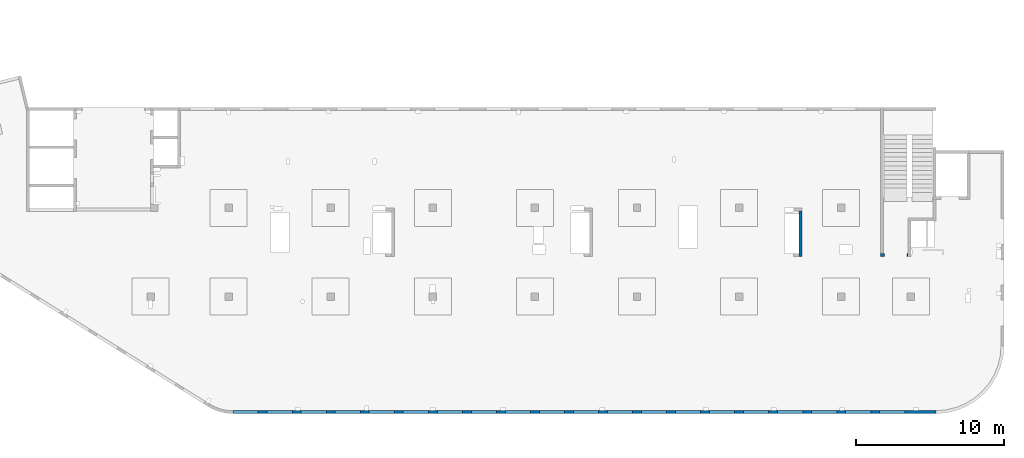
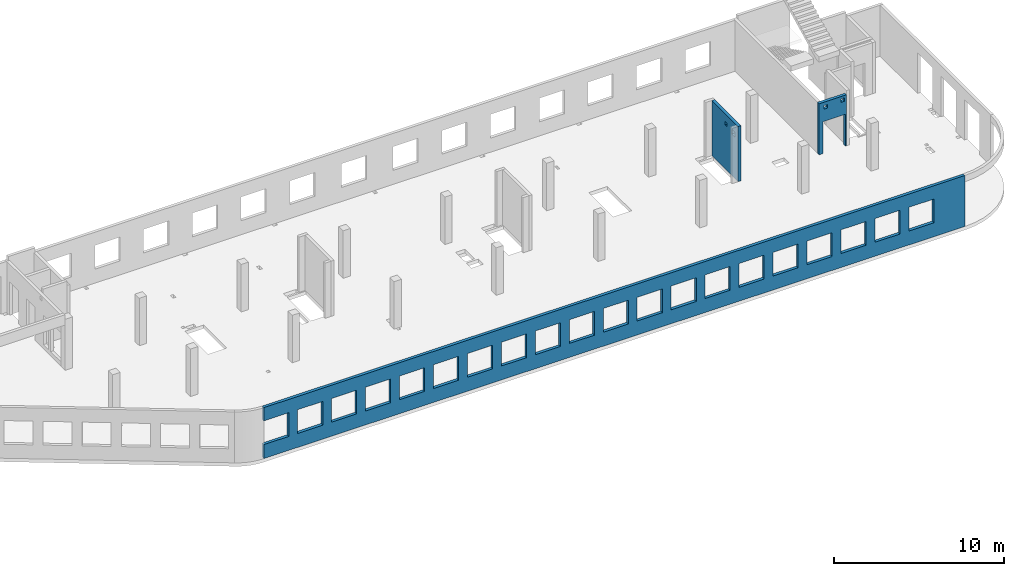
# One storey, part 91 of 92: 3 walls, 25 openings.
"""IFC4 building model written with IfcOpenShell, lengths in millimetres."""

from ifc_helpers import new_model, entity, si_unit, converted_unit, derived_unit, direction, frame, origin, place, context, subcontext, project, spatial, indexed_curve, outline, extrude, polygons, material, type_object, element, save


model = new_model("IFC4")

# Units and contexts
model_context = context("Model", 3, precision=0.01, world=origin(), true_north=direction((6.12303176911189e-17, 1.0)))
plan_context = context("Plan", 3, precision=0.01, world=origin(), true_north=direction((6.12303176911189e-17, 1.0)))
body_context = subcontext(model_context, "Body", "Model", "MODEL_VIEW")
ifc_project = project(units=[si_unit("LENGTHUNIT", "METRE", prefix="MILLI"), si_unit("AREAUNIT", "SQUARE_METRE"), si_unit("VOLUMEUNIT", "CUBIC_METRE"), converted_unit("PLANEANGLEUNIT", "DEGREE", entity("IfcRatioMeasure", 0.0174532925199433), si_unit("PLANEANGLEUNIT", "RADIAN"), dimensions=[0, 0, 0, 0, 0, 0, 0]), si_unit("MASSUNIT", "GRAM", prefix="KILO"), derived_unit("MASSDENSITYUNIT", [(si_unit("MASSUNIT", "GRAM", prefix="KILO"), 1), (si_unit("LENGTHUNIT", "METRE"), -3)]), derived_unit("MOMENTOFINERTIAUNIT", [(si_unit("LENGTHUNIT", "METRE"), 4)]), si_unit("TIMEUNIT", "SECOND"), si_unit("FREQUENCYUNIT", "HERTZ"), si_unit("THERMODYNAMICTEMPERATUREUNIT", "DEGREE_CELSIUS"), derived_unit("THERMALTRANSMITTANCEUNIT", [(si_unit("MASSUNIT", "GRAM", prefix="KILO"), 1), (si_unit("THERMODYNAMICTEMPERATUREUNIT", "KELVIN"), -1), (si_unit("TIMEUNIT", "SECOND"), -3)]), derived_unit("VOLUMETRICFLOWRATEUNIT", [(si_unit("LENGTHUNIT", "METRE"), 3), (si_unit("TIMEUNIT", "SECOND"), -1)]), derived_unit("MASSFLOWRATEUNIT", [(si_unit("MASSUNIT", "GRAM", prefix="KILO"), 1), (si_unit("TIMEUNIT", "SECOND"), -1)]), derived_unit("ROTATIONALFREQUENCYUNIT", [(si_unit("TIMEUNIT", "SECOND"), -1)]), si_unit("ELECTRICCURRENTUNIT", "AMPERE"), si_unit("ELECTRICVOLTAGEUNIT", "VOLT"), si_unit("POWERUNIT", "WATT"), si_unit("FORCEUNIT", "NEWTON", prefix="KILO"), si_unit("ILLUMINANCEUNIT", "LUX"), si_unit("LUMINOUSFLUXUNIT", "LUMEN"), si_unit("LUMINOUSINTENSITYUNIT", "CANDELA"), derived_unit("USERDEFINED", [(si_unit("MASSUNIT", "GRAM", prefix="KILO"), -1), (si_unit("LENGTHUNIT", "METRE"), -2), (si_unit("TIMEUNIT", "SECOND"), 3), (si_unit("LUMINOUSFLUXUNIT", "LUMEN"), 1)]), derived_unit("LINEARVELOCITYUNIT", [(si_unit("LENGTHUNIT", "METRE"), 1), (si_unit("TIMEUNIT", "SECOND"), -1)]), si_unit("PRESSUREUNIT", "PASCAL"), derived_unit("USERDEFINED", [(si_unit("LENGTHUNIT", "METRE"), -2), (si_unit("MASSUNIT", "GRAM", prefix="KILO"), 1), (si_unit("TIMEUNIT", "SECOND"), -2)]), derived_unit("LINEARFORCEUNIT", [(si_unit("MASSUNIT", "GRAM", prefix="KILO"), 1), (si_unit("LENGTHUNIT", "METRE"), 1), (si_unit("TIMEUNIT", "SECOND"), -2), (si_unit("LENGTHUNIT", "METRE"), -1)]), derived_unit("PLANARFORCEUNIT", [(si_unit("MASSUNIT", "GRAM", prefix="KILO"), 1), (si_unit("LENGTHUNIT", "METRE"), 1), (si_unit("TIMEUNIT", "SECOND"), -2), (si_unit("LENGTHUNIT", "METRE"), -2)])], contexts=[model_context, plan_context])

# Site, building, storey
site_placement = place(None, origin())
site = spatial("IfcSite", under=ifc_project, at=site_placement, CompositionType="ELEMENT")
building_placement = place(site_placement, origin())
building = spatial("IfcBuilding", under=site, at=building_placement, CompositionType="ELEMENT")
storey_placement = place(building_placement, frame((0.0, 0.0, 15900.0)))
storey = spatial("IfcBuildingStorey", under=building, at=storey_placement, Name="05", CompositionType="ELEMENT", Elevation=15900.0)

# Wall, openings
ifc_material = material()
wall_type = type_object("IfcWallType", Name=":ADSK_ 25_200", PredefinedType="STANDARD")
wall_1_placement = place(storey_placement, frame((67080.0, 10525.0, -150.0), z_axis=(0.0, 0.0, 1.0), x_axis=(-1.0, 0.0, 0.0)))
wall_1 = element("IfcWall", 1, at=wall_1_placement, inside=storey, type_object=wall_type, material=ifc_material, Name=":ADSK_ 25_200", ObjectType=":ADSK_ 25_200", PredefinedType="NOTDEFINED", context=body_context, shape_type="Tessellation", body=[
    polygons([(1849.99999999999, -100.000000000001, 3650.0), (1650.0, -100.000000000003, 3650.0), (-9.772240076716e-13, -100.000000000001, 3650.0), (-9.772240076716e-13, -100.000000000001, -2.16573425859679e-12), (74.9999999999906, -100.000000000001, -2.16573425859679e-12), (74.9999999999906, -100.000000000001, 2279.99999999805), (1575.0, -100.000000000001, 2279.99999999804), (1575.0, -100.000000000003, -2.16573425859679e-12), (1650.0, -100.000000000003, 0.0), (1849.99999999999, -100.000000000001, -2.16573425859679e-12), (125.000000000014, -100.000000000322, 3490.0), (375.000000000009, -100.000000000324, 3490.0), (375.000000000009, -100.000000000324, 3240.00000000001), (125.000000000014, -100.000000000322, 3240.00000000001), (1275.0, -100.000000000322, 3400.0), (1524.99999999999, -100.000000000322, 3400.0), (1524.99999999999, -100.000000000322, 3150.00000000001), (1275.0, -100.000000000322, 3150.00000000001), (-1.61109744921212e-12, 99.9999999999989, 3650.0), (1849.99999999999, 99.9999999999989, 3650.0), (1849.99999999999, 99.9999999999989, -2.16573425859679e-12), (1575.0, 99.9999999999968, -2.16573425859679e-12), (1575.0, 99.9999999999968, 2279.99999999804), (74.99999999999, 99.9999999999989, 2279.99999999805), (74.99999999999, 99.9999999999989, -2.16573425859679e-12), (-1.61109744921212e-12, 99.9999999999989, -2.16573425859679e-12), (375.000000000008, 99.9999999999968, 3490.0), (125.000000000013, 99.9999999999968, 3490.0), (125.000000000013, 99.9999999999968, 3240.00000000001), (375.000000000008, 99.9999999999968, 3240.00000000001), (1524.99999999999, 99.9999999999968, 3400.0), (1275.0, 99.9999999999989, 3400.0), (1275.0, 99.9999999999989, 3150.00000000001), (1524.99999999999, 99.9999999999968, 3150.00000000001)], [[[1, 2, 3, 4, 5, 6, 7, 8, 9, 10], [11, 12, 13, 14], [15, 16, 17, 18]], [[19, 20, 21, 22, 23, 24, 25, 26], [27, 28, 29, 30], [31, 32, 33, 34]], [[4, 26, 25, 5]], [[3, 2, 1, 20, 19]], [[4, 3, 19, 26]], [[1, 10, 21, 20]], [[12, 11, 28, 27]], [[12, 27, 30, 13]], [[13, 30, 29, 14]], [[28, 11, 14, 29]], [[16, 15, 32, 31]], [[16, 31, 34, 17]], [[17, 34, 33, 18]], [[32, 15, 18, 33]], [[6, 24, 23, 7]], [[7, 23, 22, 8]], [[24, 6, 5, 25]], [[21, 10, 9, 8, 22]]], closed=True),
])
placement_1 = place(wall_1_placement, frame((67080.0, 10525.0, 150.0), z_axis=(0.0, 0.0, 1.0), x_axis=(-1.0, 0.0, 0.0)))
element("IfcOpeningElement", 2, at=placement_1, cuts=wall_1, Name=":ADSK_ 25_200", PredefinedType="OPENING", context=body_context, shape_type="SweptSolid", body=[
    extrude(outline(indexed_curve([(-750.000000000003, -1139.99999999902), (749.999999999994, -1139.99999999902), (749.999999999994, 1139.99999999902), (-750.000000000003, 1139.99999999902), (-750.000000000003, -1139.99999999902)], self_intersect=False)), frame((66255.0, 10725.0, 990.0), z_axis=(0.0, -1.0, 0.0), x_axis=(-1.0, 0.0, 0.0)), (0.0, 0.0, 1.0), 400.000000001943),
])
element("IfcOpeningElement", 3, at=placement_1, cuts=wall_1, Name=":ADSK_ 25_200", PredefinedType="OPENING", context=body_context, shape_type="SweptSolid", body=[
    extrude(outline(indexed_curve([(-125.000000000006, -124.999999999993), (124.999999999998, -124.999999999993), (124.999999999998, 124.999999999993), (-125.000000000006, 124.999999999993), (-125.000000000006, -124.999999999993)], self_intersect=False)), frame((65680.0, 10625.0, 3125.0), z_axis=(0.0, -1.0, 0.0), x_axis=(-1.0, 0.0, 0.0)), (0.0, 0.0, 1.0), 200.000000000962),
])
element("IfcOpeningElement", 4, at=placement_1, cuts=wall_1, Name=":ADSK_ 25_200", PredefinedType="OPENING", context=body_context, shape_type="SweptSolid", body=[
    extrude(outline(indexed_curve([(-125.000000000006, -124.999999999993), (124.999999999998, -124.999999999993), (124.999999999998, 124.999999999993), (-125.000000000006, 124.999999999993), (-125.000000000006, -124.999999999993)], self_intersect=False)), frame((66830.0, 10625.0, 3215.0), z_axis=(0.0, -1.0, 0.0), x_axis=(-1.0, 0.0, 0.0)), (0.0, 0.0, 1.0), 200.000000000962),
])

wall_2_placement = place(storey_placement, frame((68970.0, -100.0, -150.0), z_axis=(0.0, 0.0, 1.0), x_axis=(-1.0, 0.0, 0.0)))
wall_2 = element("IfcWall", 5, at=wall_2_placement, inside=storey, type_object=wall_type, material=ifc_material, Name=":ADSK_ 25_200", ObjectType=":ADSK_ 25_200", PredefinedType="NOTDEFINED", context=body_context, shape_type="Tessellation", body=[
    polygons([(8.66293717728731e-12, -100.0, -2.16573425859679e-12), (47500.0, -100.0, -2.16573425859679e-12), (47500.0, -100.0, 1000.00000000001), (45800.0, -100.000000000321, 1000.00000000001), (45800.0, -100.000000000321, 2700.0), (47500.0, -100.0, 2700.0), (47500.0, -100.0, 3650.0), (8.66293717728731e-12, -100.0, 3650.0), (1.42900165493394e-19, -100.0, 3200.0), (43500.0, -100.000000000321, 2700.0), (45200.0, -100.000000000321, 2700.0), (45200.0, -100.000000000321, 1000.00000000001), (43500.0, -100.000000000321, 1000.00000000001), (41200.0, -100.000000000321, 2700.0), (42900.0, -100.000000000321, 2700.0), (42900.0, -100.000000000321, 1000.00000000001), (41200.0, -100.000000000321, 1000.00000000001), (38900.0, -100.000000000321, 2700.0), (40600.0, -100.000000000321, 2700.0), (40600.0, -100.000000000321, 1000.00000000001), (38900.0, -100.000000000321, 1000.00000000001), (36600.0, -100.000000000321, 2700.0), (38300.0, -100.000000000321, 2700.0), (38300.0, -100.000000000321, 1000.00000000001), (36600.0, -100.000000000321, 1000.00000000001), (34300.0, -100.000000000321, 2700.0), (36000.0, -100.000000000321, 2700.0), (36000.0, -100.000000000321, 1000.00000000001), (34300.0, -100.000000000321, 1000.00000000001), (32000.0, -100.000000000321, 2700.0), (33700.0, -100.000000000321, 2700.0), (33700.0, -100.000000000321, 1000.00000000001), (32000.0, -100.000000000321, 1000.00000000001), (29700.0, -100.000000000321, 2700.0), (31400.0, -100.000000000321, 2700.0), (31400.0, -100.000000000321, 1000.00000000001), (29700.0, -100.000000000321, 1000.00000000001), (27400.0, -100.000000000321, 2700.0), (29100.0, -100.000000000321, 2700.0), (29100.0, -100.000000000321, 1000.00000000001), (27400.0, -100.000000000321, 1000.00000000001), (25100.0, -100.000000000321, 2700.0), (26800.0, -100.000000000321, 2700.0), (26800.0, -100.000000000321, 1000.00000000001), (25100.0, -100.000000000321, 1000.00000000001), (22800.0, -100.000000000321, 2700.0), (24500.0, -100.000000000321, 2700.0), (24500.0, -100.000000000321, 1000.00000000001), (22800.0, -100.000000000321, 1000.00000000001), (20500.0, -100.000000000321, 2700.0), (22200.0, -100.000000000321, 2700.0), (22200.0, -100.000000000321, 1000.00000000001), (20500.0, -100.000000000321, 1000.00000000001), (18200.0, -100.000000000321, 2700.0), (19900.0, -100.000000000321, 2700.0), (19900.0, -100.000000000321, 1000.00000000001), (18200.0, -100.000000000321, 1000.00000000001), (15900.0, -100.000000000321, 2700.0), (17600.0, -100.000000000321, 2700.0), (17600.0, -100.000000000321, 1000.00000000001), (15900.0, -100.000000000321, 1000.00000000001), (13600.0, -100.000000000321, 2700.0), (15300.0, -100.000000000321, 2700.0), (15300.0, -100.000000000321, 1000.00000000001), (13600.0, -100.000000000321, 1000.00000000001), (11300.0, -100.000000000321, 2700.0), (13000.0, -100.000000000321, 2700.0), (13000.0, -100.000000000321, 1000.00000000001), (11300.0, -100.000000000321, 1000.00000000001), (8999.99999999998, -100.000000000321, 2700.0), (10700.0, -100.000000000321, 2700.0), (10700.0, -100.000000000321, 1000.00000000001), (8999.99999999998, -100.000000000321, 1000.00000000001), (6699.99999999998, -100.000000000321, 2700.0), (8399.99999999997, -100.000000000321, 2700.0), (8399.99999999997, -100.000000000321, 1000.00000000001), (6699.99999999998, -100.000000000321, 1000.00000000001), (4399.99999999998, -100.000000000321, 2700.0), (6099.99999999997, -100.000000000321, 2700.0), (6099.99999999997, -100.000000000321, 1000.00000000001), (4399.99999999998, -100.000000000321, 1000.00000000001), (2099.99999999998, -100.000000000321, 2700.0), (3799.99999999998, -100.000000000321, 2700.0), (3799.99999999998, -100.000000000321, 1000.00000000001), (2099.99999999998, -100.000000000321, 1000.00000000001), (47500.0, 100.0, -2.16573425859679e-12), (8.01671852045731e-12, 100.0, -2.16573425859679e-12), (-6.46218513929826e-13, 100.0, 3200.0), (8.01671852045731e-12, 100.0, 3650.0), (47500.0, 100.0, 3650.0), (47500.0, 100.0, 2700.0), (45800.0, 100.0, 2700.0), (45800.0, 100.0, 1000.00000000001), (47500.0, 100.0, 1000.00000000001), (45200.0, 100.0, 2700.0), (43500.0, 100.0, 2700.0), (43500.0, 100.0, 1000.00000000001), (45200.0, 100.0, 1000.00000000001), (42900.0, 100.0, 2700.0), (41200.0, 100.0, 2700.0), (41200.0, 100.0, 1000.00000000001), (42900.0, 100.0, 1000.00000000001), (40600.0, 100.0, 2700.0), (38900.0, 100.0, 2700.0), (38900.0, 100.0, 1000.00000000001), (40600.0, 100.0, 1000.00000000001), (38300.0, 100.0, 2700.0), (36600.0, 100.0, 2700.0), (36600.0, 100.0, 1000.00000000001), (38300.0, 100.0, 1000.00000000001), (36000.0, 100.0, 2700.0), (34300.0, 100.0, 2700.0), (34300.0, 100.0, 1000.00000000001), (36000.0, 100.0, 1000.00000000001), (33700.0, 100.0, 2700.0), (32000.0, 100.0, 2700.0), (32000.0, 100.0, 1000.00000000001), (33700.0, 100.0, 1000.00000000001), (31400.0, 100.0, 2700.0), (29700.0, 100.0, 2700.0), (29700.0, 100.0, 1000.00000000001), (31400.0, 100.0, 1000.00000000001), (29100.0, 100.0, 2700.0), (27400.0, 100.0, 2700.0), (27400.0, 100.0, 1000.00000000001), (29100.0, 100.0, 1000.00000000001), (26800.0, 100.0, 2700.0), (25100.0, 100.0, 2700.0), (25100.0, 100.0, 1000.00000000001), (26800.0, 100.0, 1000.00000000001), (24500.0, 100.0, 2700.0), (22800.0, 100.0, 2700.0), (22800.0, 100.0, 1000.00000000001), (24500.0, 100.0, 1000.00000000001), (22200.0, 100.0, 2700.0), (20500.0, 100.0, 2700.0), (20500.0, 100.0, 1000.00000000001), (22200.0, 100.0, 1000.00000000001), (19900.0, 100.0, 2700.0), (18200.0, 100.0, 2700.0), (18200.0, 100.0, 1000.00000000001), (19900.0, 100.0, 1000.00000000001), (17600.0, 100.0, 2700.0), (15900.0, 100.0, 2700.0), (15900.0, 100.0, 1000.00000000001), (17600.0, 100.0, 1000.00000000001), (15300.0, 100.0, 2700.0), (13600.0, 100.0, 2700.0), (13600.0, 100.0, 1000.00000000001), (15300.0, 100.0, 1000.00000000001), (13000.0, 100.0, 2700.0), (11300.0, 100.0, 2700.0), (11300.0, 100.0, 1000.00000000001), (13000.0, 100.0, 1000.00000000001), (10700.0, 100.0, 2700.0), (8999.99999999998, 100.0, 2700.0), (8999.99999999998, 100.0, 1000.00000000001), (10700.0, 100.0, 1000.00000000001), (8399.99999999997, 100.0, 2700.0), (6699.99999999997, 100.0, 2700.0), (6699.99999999997, 100.0, 1000.00000000001), (8399.99999999997, 100.0, 1000.00000000001), (6099.99999999997, 100.0, 2700.0), (4399.99999999998, 100.0, 2700.0), (4399.99999999998, 100.0, 1000.00000000001), (6099.99999999997, 100.0, 1000.00000000001), (3799.99999999998, 100.0, 2700.0), (2099.99999999998, 100.0, 2700.0), (2099.99999999998, 100.0, 1000.00000000001), (3799.99999999998, 100.0, 1000.00000000001)], [[[1, 2, 3, 4, 5, 6, 7, 8, 9], [10, 11, 12, 13], [14, 15, 16, 17], [18, 19, 20, 21], [22, 23, 24, 25], [26, 27, 28, 29], [30, 31, 32, 33], [34, 35, 36, 37], [38, 39, 40, 41], [42, 43, 44, 45], [46, 47, 48, 49], [50, 51, 52, 53], [54, 55, 56, 57], [58, 59, 60, 61], [62, 63, 64, 65], [66, 67, 68, 69], [70, 71, 72, 73], [74, 75, 76, 77], [78, 79, 80, 81], [82, 83, 84, 85]], [[86, 87, 88, 89, 90, 91, 92, 93, 94], [95, 96, 97, 98], [99, 100, 101, 102], [103, 104, 105, 106], [107, 108, 109, 110], [111, 112, 113, 114], [115, 116, 117, 118], [119, 120, 121, 122], [123, 124, 125, 126], [127, 128, 129, 130], [131, 132, 133, 134], [135, 136, 137, 138], [139, 140, 141, 142], [143, 144, 145, 146], [147, 148, 149, 150], [151, 152, 153, 154], [155, 156, 157, 158], [159, 160, 161, 162], [163, 164, 165, 166], [167, 168, 169, 170]], [[2, 1, 87, 86]], [[2, 86, 94, 3]], [[8, 7, 90, 89]], [[1, 9, 8, 89, 88, 87]], [[5, 92, 91, 6]], [[93, 4, 3, 94]], [[92, 5, 4, 93]], [[11, 10, 96, 95]], [[11, 95, 98, 12]], [[12, 98, 97, 13]], [[96, 10, 13, 97]], [[15, 14, 100, 99]], [[15, 99, 102, 16]], [[16, 102, 101, 17]], [[100, 14, 17, 101]], [[19, 18, 104, 103]], [[19, 103, 106, 20]], [[20, 106, 105, 21]], [[104, 18, 21, 105]], [[23, 22, 108, 107]], [[23, 107, 110, 24]], [[24, 110, 109, 25]], [[108, 22, 25, 109]], [[27, 26, 112, 111]], [[27, 111, 114, 28]], [[28, 114, 113, 29]], [[112, 26, 29, 113]], [[31, 30, 116, 115]], [[31, 115, 118, 32]], [[32, 118, 117, 33]], [[116, 30, 33, 117]], [[35, 34, 120, 119]], [[35, 119, 122, 36]], [[36, 122, 121, 37]], [[120, 34, 37, 121]], [[39, 38, 124, 123]], [[39, 123, 126, 40]], [[40, 126, 125, 41]], [[124, 38, 41, 125]], [[43, 42, 128, 127]], [[43, 127, 130, 44]], [[44, 130, 129, 45]], [[128, 42, 45, 129]], [[47, 46, 132, 131]], [[47, 131, 134, 48]], [[48, 134, 133, 49]], [[132, 46, 49, 133]], [[51, 50, 136, 135]], [[51, 135, 138, 52]], [[52, 138, 137, 53]], [[136, 50, 53, 137]], [[55, 54, 140, 139]], [[55, 139, 142, 56]], [[56, 142, 141, 57]], [[140, 54, 57, 141]], [[59, 58, 144, 143]], [[59, 143, 146, 60]], [[60, 146, 145, 61]], [[144, 58, 61, 145]], [[63, 62, 148, 147]], [[63, 147, 150, 64]], [[64, 150, 149, 65]], [[148, 62, 65, 149]], [[67, 66, 152, 151]], [[67, 151, 154, 68]], [[68, 154, 153, 69]], [[152, 66, 69, 153]], [[71, 70, 156, 155]], [[71, 155, 158, 72]], [[72, 158, 157, 73]], [[156, 70, 73, 157]], [[75, 74, 160, 159]], [[75, 159, 162, 76]], [[76, 162, 161, 77]], [[160, 74, 77, 161]], [[79, 78, 164, 163]], [[79, 163, 166, 80]], [[80, 166, 165, 81]], [[164, 78, 81, 165]], [[83, 82, 168, 167]], [[83, 167, 170, 84]], [[84, 170, 169, 85]], [[168, 82, 85, 169]], [[90, 7, 6, 91]]], closed=True),
])
placement_2 = place(wall_2_placement, frame((68970.0, -100.0, 150.0), z_axis=(0.0, 0.0, 1.0), x_axis=(-1.0, 0.0, 0.0)))
element("IfcOpeningElement", 6, at=placement_2, cuts=wall_2, Name=":ADSK_ 25_200", PredefinedType="OPENING", context=body_context, shape_type="SweptSolid", body=[
    extrude(outline(indexed_curve([(-850.000000000002, -849.999999999993), (849.999999999997, -849.999999999993), (849.999999999997, 849.999999999995), (-850.000000000002, 849.999999999995), (-850.000000000002, -849.999999999993)], self_intersect=False)), frame((22320.0, 0.0, 1700.0), z_axis=(0.0, -1.0, 0.0), x_axis=(-1.0, 0.0, 0.0)), (0.0, 0.0, 1.0), 200.000000000962),
])
element("IfcOpeningElement", 7, at=placement_2, cuts=wall_2, Name=":ADSK_ 25_200", PredefinedType="OPENING", context=body_context, shape_type="SweptSolid", body=[
    extrude(outline(indexed_curve([(-849.999999999997, -849.999999999993), (850.000000000006, -849.999999999993), (850.000000000006, 849.999999999995), (-849.999999999997, 849.999999999995), (-849.999999999997, -849.999999999993)], self_intersect=False)), frame((66020.0, 0.0, 1700.0), z_axis=(0.0, -1.0, 0.0), x_axis=(-1.0, 0.0, 0.0)), (0.0, 0.0, 1.0), 200.000000000962),
])
element("IfcOpeningElement", 8, at=placement_2, cuts=wall_2, Name=":ADSK_ 25_200", PredefinedType="OPENING", context=body_context, shape_type="SweptSolid", body=[
    extrude(outline(indexed_curve([(-849.999999999997, -849.999999999993), (850.000000000006, -849.999999999993), (850.000000000006, 849.999999999995), (-849.999999999997, 849.999999999995), (-849.999999999997, -849.999999999993)], self_intersect=False)), frame((63720.0, 0.0, 1700.0), z_axis=(0.0, -1.0, 0.0), x_axis=(-1.0, 0.0, 0.0)), (0.0, 0.0, 1.0), 200.000000000962),
])
element("IfcOpeningElement", 9, at=placement_2, cuts=wall_2, Name=":ADSK_ 25_200", PredefinedType="OPENING", context=body_context, shape_type="SweptSolid", body=[
    extrude(outline(indexed_curve([(-849.999999999997, -849.999999999993), (850.000000000006, -849.999999999993), (850.000000000006, 849.999999999995), (-849.999999999997, 849.999999999995), (-849.999999999997, -849.999999999993)], self_intersect=False)), frame((61420.0, 0.0, 1700.0), z_axis=(0.0, -1.0, 0.0), x_axis=(-1.0, 0.0, 0.0)), (0.0, 0.0, 1.0), 200.000000000962),
])
element("IfcOpeningElement", 10, at=placement_2, cuts=wall_2, Name=":ADSK_ 25_200", PredefinedType="OPENING", context=body_context, shape_type="SweptSolid", body=[
    extrude(outline(indexed_curve([(-849.999999999997, -849.999999999993), (850.000000000006, -849.999999999993), (850.000000000006, 849.999999999995), (-849.999999999997, 849.999999999995), (-849.999999999997, -849.999999999993)], self_intersect=False)), frame((59120.0, 0.0, 1700.0), z_axis=(0.0, -1.0, 0.0), x_axis=(-1.0, 0.0, 0.0)), (0.0, 0.0, 1.0), 200.000000000962),
])
element("IfcOpeningElement", 11, at=placement_2, cuts=wall_2, Name=":ADSK_ 25_200", PredefinedType="OPENING", context=body_context, shape_type="SweptSolid", body=[
    extrude(outline(indexed_curve([(-849.999999999997, -849.999999999993), (850.000000000006, -849.999999999993), (850.000000000006, 849.999999999995), (-849.999999999997, 849.999999999995), (-849.999999999997, -849.999999999993)], self_intersect=False)), frame((56820.0, 0.0, 1700.0), z_axis=(0.0, -1.0, 0.0), x_axis=(-1.0, 0.0, 0.0)), (0.0, 0.0, 1.0), 200.000000000962),
])
element("IfcOpeningElement", 12, at=placement_2, cuts=wall_2, Name=":ADSK_ 25_200", PredefinedType="OPENING", context=body_context, shape_type="SweptSolid", body=[
    extrude(outline(indexed_curve([(-849.999999999997, -849.999999999993), (850.000000000006, -849.999999999993), (850.000000000006, 849.999999999995), (-849.999999999997, 849.999999999995), (-849.999999999997, -849.999999999993)], self_intersect=False)), frame((54520.0, 0.0, 1700.0), z_axis=(0.0, -1.0, 0.0), x_axis=(-1.0, 0.0, 0.0)), (0.0, 0.0, 1.0), 200.000000000962),
])
element("IfcOpeningElement", 13, at=placement_2, cuts=wall_2, Name=":ADSK_ 25_200", PredefinedType="OPENING", context=body_context, shape_type="SweptSolid", body=[
    extrude(outline(indexed_curve([(-849.999999999997, -849.999999999993), (850.000000000006, -849.999999999993), (850.000000000006, 849.999999999995), (-849.999999999997, 849.999999999995), (-849.999999999997, -849.999999999993)], self_intersect=False)), frame((52220.0, 0.0, 1700.0), z_axis=(0.0, -1.0, 0.0), x_axis=(-1.0, 0.0, 0.0)), (0.0, 0.0, 1.0), 200.000000000962),
])
element("IfcOpeningElement", 14, at=placement_2, cuts=wall_2, Name=":ADSK_ 25_200", PredefinedType="OPENING", context=body_context, shape_type="SweptSolid", body=[
    extrude(outline(indexed_curve([(-849.999999999997, -849.999999999993), (850.000000000006, -849.999999999993), (850.000000000006, 849.999999999995), (-849.999999999997, 849.999999999995), (-849.999999999997, -849.999999999993)], self_intersect=False)), frame((49920.0, 0.0, 1700.0), z_axis=(0.0, -1.0, 0.0), x_axis=(-1.0, 0.0, 0.0)), (0.0, 0.0, 1.0), 200.000000000962),
])
element("IfcOpeningElement", 15, at=placement_2, cuts=wall_2, Name=":ADSK_ 25_200", PredefinedType="OPENING", context=body_context, shape_type="SweptSolid", body=[
    extrude(outline(indexed_curve([(-849.999999999997, -849.999999999993), (850.000000000006, -849.999999999993), (850.000000000006, 849.999999999995), (-849.999999999997, 849.999999999995), (-849.999999999997, -849.999999999993)], self_intersect=False)), frame((47620.0, 0.0, 1700.0), z_axis=(0.0, -1.0, 0.0), x_axis=(-1.0, 0.0, 0.0)), (0.0, 0.0, 1.0), 200.000000000962),
])
element("IfcOpeningElement", 16, at=placement_2, cuts=wall_2, Name=":ADSK_ 25_200", PredefinedType="OPENING", context=body_context, shape_type="SweptSolid", body=[
    extrude(outline(indexed_curve([(-849.999999999997, -849.999999999993), (850.000000000006, -849.999999999993), (850.000000000006, 849.999999999995), (-849.999999999997, 849.999999999995), (-849.999999999997, -849.999999999993)], self_intersect=False)), frame((45320.0, 0.0, 1700.0), z_axis=(0.0, -1.0, 0.0), x_axis=(-1.0, 0.0, 0.0)), (0.0, 0.0, 1.0), 200.000000000962),
])
element("IfcOpeningElement", 17, at=placement_2, cuts=wall_2, Name=":ADSK_ 25_200", PredefinedType="OPENING", context=body_context, shape_type="SweptSolid", body=[
    extrude(outline(indexed_curve([(-849.999999999997, -849.999999999993), (850.000000000006, -849.999999999993), (850.000000000006, 849.999999999995), (-849.999999999997, 849.999999999995), (-849.999999999997, -849.999999999993)], self_intersect=False)), frame((43020.0, 0.0, 1700.0), z_axis=(0.0, -1.0, 0.0), x_axis=(-1.0, 0.0, 0.0)), (0.0, 0.0, 1.0), 200.000000000962),
])
element("IfcOpeningElement", 18, at=placement_2, cuts=wall_2, Name=":ADSK_ 25_200", PredefinedType="OPENING", context=body_context, shape_type="SweptSolid", body=[
    extrude(outline(indexed_curve([(-849.999999999997, -849.999999999993), (850.000000000006, -849.999999999993), (850.000000000006, 849.999999999995), (-849.999999999997, 849.999999999995), (-849.999999999997, -849.999999999993)], self_intersect=False)), frame((40720.0, 0.0, 1700.0), z_axis=(0.0, -1.0, 0.0), x_axis=(-1.0, 0.0, 0.0)), (0.0, 0.0, 1.0), 200.000000000962),
])
element("IfcOpeningElement", 19, at=placement_2, cuts=wall_2, Name=":ADSK_ 25_200", PredefinedType="OPENING", context=body_context, shape_type="SweptSolid", body=[
    extrude(outline(indexed_curve([(-849.999999999997, -849.999999999993), (850.000000000002, -849.999999999993), (850.000000000002, 849.999999999995), (-849.999999999997, 849.999999999995), (-849.999999999997, -849.999999999993)], self_intersect=False)), frame((38420.0, 0.0, 1700.0), z_axis=(0.0, -1.0, 0.0), x_axis=(-1.0, 0.0, 0.0)), (0.0, 0.0, 1.0), 200.000000000962),
])
element("IfcOpeningElement", 20, at=placement_2, cuts=wall_2, Name=":ADSK_ 25_200", PredefinedType="OPENING", context=body_context, shape_type="SweptSolid", body=[
    extrude(outline(indexed_curve([(-849.999999999997, -849.999999999993), (850.000000000002, -849.999999999993), (850.000000000002, 849.999999999995), (-849.999999999997, 849.999999999995), (-849.999999999997, -849.999999999993)], self_intersect=False)), frame((36120.0, 0.0, 1700.0), z_axis=(0.0, -1.0, 0.0), x_axis=(-1.0, 0.0, 0.0)), (0.0, 0.0, 1.0), 200.000000000962),
])
element("IfcOpeningElement", 21, at=placement_2, cuts=wall_2, Name=":ADSK_ 25_200", PredefinedType="OPENING", context=body_context, shape_type="SweptSolid", body=[
    extrude(outline(indexed_curve([(-849.999999999997, -849.999999999993), (850.000000000002, -849.999999999993), (850.000000000002, 849.999999999995), (-849.999999999997, 849.999999999995), (-849.999999999997, -849.999999999993)], self_intersect=False)), frame((33820.0, 0.0, 1700.0), z_axis=(0.0, -1.0, 0.0), x_axis=(-1.0, 0.0, 0.0)), (0.0, 0.0, 1.0), 200.000000000962),
])
element("IfcOpeningElement", 22, at=placement_2, cuts=wall_2, Name=":ADSK_ 25_200", PredefinedType="OPENING", context=body_context, shape_type="SweptSolid", body=[
    extrude(outline(indexed_curve([(-849.999999999997, -849.999999999993), (850.000000000002, -849.999999999993), (850.000000000002, 849.999999999995), (-849.999999999997, 849.999999999995), (-849.999999999997, -849.999999999993)], self_intersect=False)), frame((31520.0, 0.0, 1700.0), z_axis=(0.0, -1.0, 0.0), x_axis=(-1.0, 0.0, 0.0)), (0.0, 0.0, 1.0), 200.000000000962),
])
element("IfcOpeningElement", 23, at=placement_2, cuts=wall_2, Name=":ADSK_ 25_200", PredefinedType="OPENING", context=body_context, shape_type="SweptSolid", body=[
    extrude(outline(indexed_curve([(-850.000000000002, -849.999999999993), (849.999999999997, -849.999999999993), (849.999999999997, 849.999999999995), (-850.000000000002, 849.999999999995), (-850.000000000002, -849.999999999993)], self_intersect=False)), frame((29220.0, 0.0, 1700.0), z_axis=(0.0, -1.0, 0.0), x_axis=(-1.0, 0.0, 0.0)), (0.0, 0.0, 1.0), 200.000000000962),
])
element("IfcOpeningElement", 24, at=placement_2, cuts=wall_2, Name=":ADSK_ 25_200", PredefinedType="OPENING", context=body_context, shape_type="SweptSolid", body=[
    extrude(outline(indexed_curve([(-850.000000000002, -849.999999999993), (849.999999999997, -849.999999999993), (849.999999999997, 849.999999999995), (-850.000000000002, 849.999999999995), (-850.000000000002, -849.999999999993)], self_intersect=False)), frame((26920.0, 0.0, 1700.0), z_axis=(0.0, -1.0, 0.0), x_axis=(-1.0, 0.0, 0.0)), (0.0, 0.0, 1.0), 200.000000000962),
])
element("IfcOpeningElement", 25, at=placement_2, cuts=wall_2, Name=":ADSK_ 25_200", PredefinedType="OPENING", context=body_context, shape_type="SweptSolid", body=[
    extrude(outline(indexed_curve([(-850.000000000002, -849.999999999993), (849.999999999997, -849.999999999993), (849.999999999997, 849.999999999995), (-850.000000000002, 849.999999999995), (-850.000000000002, -849.999999999993)], self_intersect=False)), frame((24620.0, 0.0, 1700.0), z_axis=(0.0, -1.0, 0.0), x_axis=(-1.0, 0.0, 0.0)), (0.0, 0.0, 1.0), 200.000000000962),
])

wall_3_placement = place(storey_placement, frame((59830.0, 13500.0, -150.0), z_axis=(0.0, 0.0, 1.0), x_axis=(0.0, -1.0, 0.0)))
wall_3 = element("IfcWall", 26, at=wall_3_placement, inside=storey, type_object=wall_type, material=ifc_material, Name=":ADSK_ 25_200", ObjectType=":ADSK_ 25_200", PredefinedType="NOTDEFINED", context=body_context, shape_type="Tessellation", body=[
    polygons([(-2.16573425859679e-12, -99.999999999987, -2.16573425859679e-12), (2875.00000000001, -99.9999999999967, 0.0), (3075.00000000001, -99.9999999999962, -2.16573425859679e-12), (3075.00000000001, -99.9999999999962, 3950.0), (2875.00000000001, -99.9999999999967, 3950.0), (-2.16573425859679e-12, -99.999999999987, 3950.0), (1560.00000000001, -100.000000000009, 3400.0), (1810.00000000001, -100.000000000008, 3400.0), (1810.00000000001, -100.000000000008, 3150.00000000001), (1560.00000000001, -100.000000000009, 3150.00000000001), (2360.00000000001, -100.000000000007, 3330.0), (2710.00000000001, -100.000000000006, 3330.0), (2710.00000000001, -100.000000000006, 2980.00000000001), (2360.00000000001, -100.000000000007, 2980.00000000001), (-2.16573425859679e-12, 100.000000000002, -2.16573425859679e-12), (-2.16573425859679e-12, 100.000000000002, 3950.0), (3075.00000000001, 99.999999999993, 3950.0), (3075.00000000001, 99.999999999993, -2.16573425859679e-12), (1810.00000000001, 100.000000000319, 3400.0), (1560.00000000001, 100.000000000318, 3400.0), (1560.00000000001, 100.000000000318, 3150.00000000001), (1810.00000000001, 100.000000000319, 3150.00000000001), (2710.00000000001, 100.000000000321, 3330.0), (2360.00000000001, 100.00000000032, 3330.0), (2360.00000000001, 100.00000000032, 2980.00000000001), (2710.00000000001, 100.000000000321, 2980.00000000001)], [[[1, 2, 3, 4, 5, 6], [7, 8, 9, 10], [11, 12, 13, 14]], [[15, 16, 17, 18], [19, 20, 21, 22], [23, 24, 25, 26]], [[3, 2, 1, 15, 18]], [[6, 5, 4, 17, 16]], [[1, 6, 16, 15]], [[4, 3, 18, 17]], [[20, 19, 8, 7]], [[20, 7, 10, 21]], [[21, 10, 9, 22]], [[8, 19, 22, 9]], [[24, 23, 12, 11]], [[24, 11, 14, 25]], [[25, 14, 13, 26]], [[12, 23, 26, 13]]], closed=True),
])
placement_3 = place(wall_3_placement, frame((13500.0, -59830.0, 150.0), z_axis=(0.0, 0.0, 1.0), x_axis=(0.0, 1.0, 0.0)))
element("IfcOpeningElement", 27, at=placement_3, cuts=wall_3, Name=":ADSK_ 25_200", PredefinedType="OPENING", context=body_context, shape_type="SweptSolid", body=[
    extrude(outline(indexed_curve([(-174.999999999995, -174.999999999999), (174.999999999991, -174.999999999999), (174.999999999991, 175.000000000001), (-174.999999999995, 175.000000000001), (-174.999999999995, -174.999999999999)], self_intersect=False)), frame((59730.0, 10965.0, 3005.0), z_axis=(1.0, 0.0, 0.0), x_axis=(0.0, 0.0, -1.0)), (0.0, 0.0, 1.0), 200.000000000968),
])
element("IfcOpeningElement", 28, at=placement_3, cuts=wall_3, Name=":ADSK_ 25_200", PredefinedType="OPENING", context=body_context, shape_type="SweptSolid", body=[
    extrude(outline(indexed_curve([(-124.999999999991, -125.0), (124.999999999993, -125.0), (124.999999999993, 125.0), (-124.999999999991, 125.0), (-124.999999999991, -125.0)], self_intersect=False)), frame((59730.0, 11815.0, 3125.0), z_axis=(1.0, 0.0, 0.0), x_axis=(0.0, 0.0, -1.0)), (0.0, 0.0, 1.0), 200.000000000968),
])

save(model, "model.ifc")
